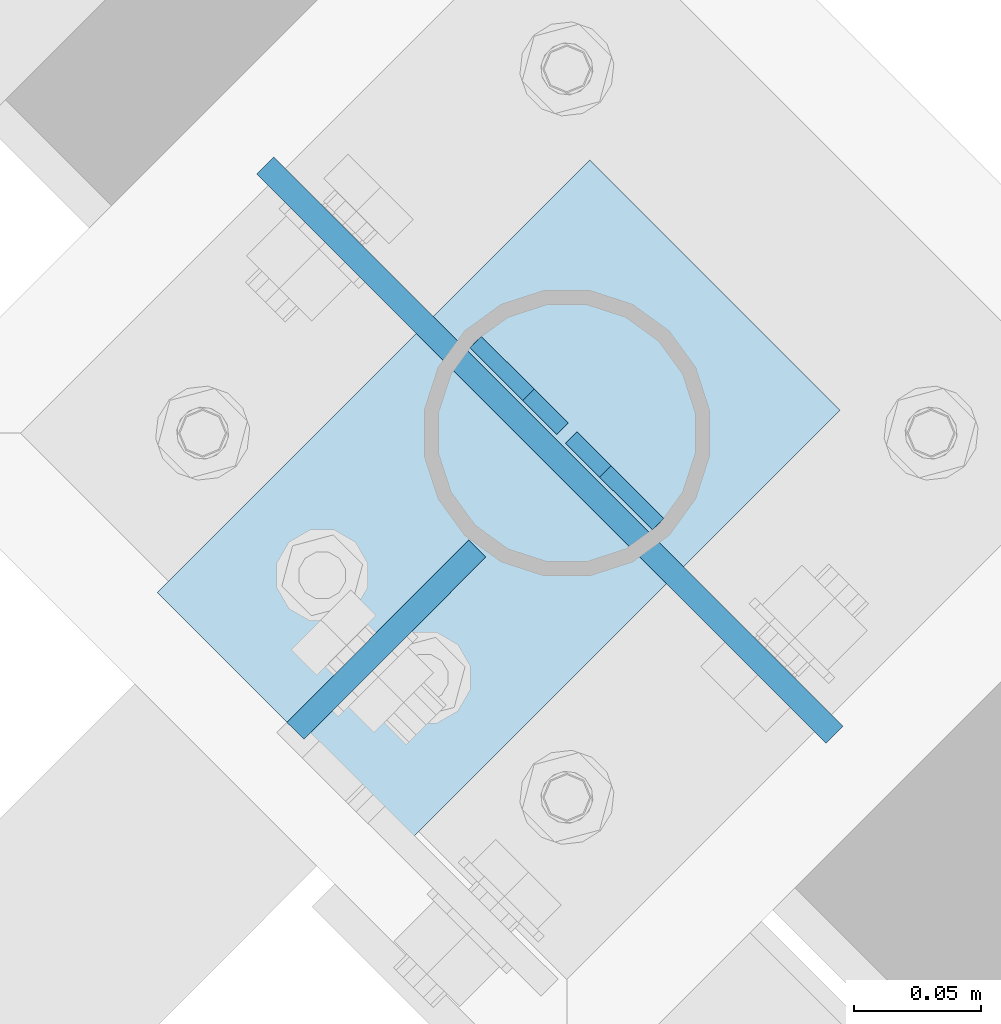
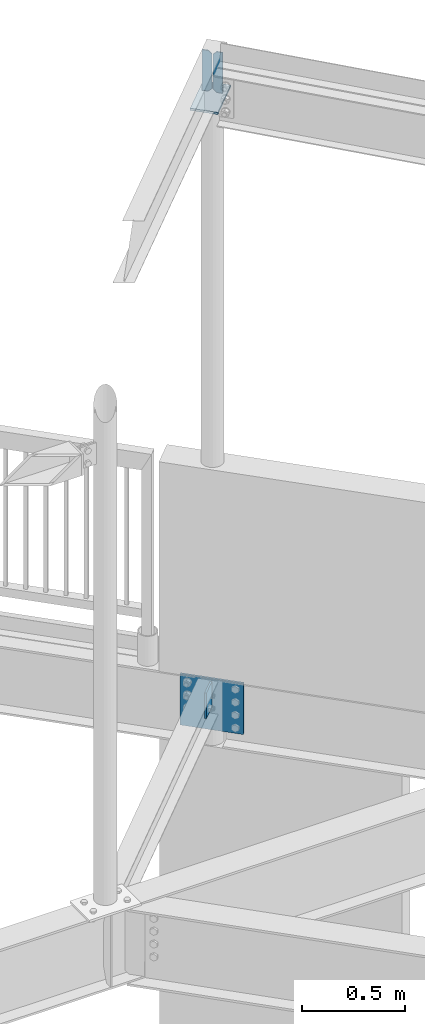
# One storey, part 869 of 975: 5 plates.
"""IFC2X3 building model written with IfcOpenShell, lengths in millimetres."""

from ifc_helpers import new_model, si_unit, frame, origin_with_axes, place, context, subcontext, project, spatial, faceted_brep, material, type_object, element, save


model = new_model("IFC2X3")

# Units and contexts
model_context = context("Model", 3, precision=1e-05, world=origin_with_axes())
body_context = subcontext(model_context, "Body", "Model", "MODEL_VIEW")
ifc_project = project(units=[si_unit("LENGTHUNIT", "METRE", prefix="MILLI"), si_unit("AREAUNIT", "SQUARE_METRE"), si_unit("VOLUMEUNIT", "CUBIC_METRE"), si_unit("MASSUNIT", "GRAM", prefix="KILO"), si_unit("TIMEUNIT", "SECOND"), si_unit("PLANEANGLEUNIT", "RADIAN"), si_unit("SOLIDANGLEUNIT", "STERADIAN"), si_unit("THERMODYNAMICTEMPERATUREUNIT", "DEGREE_CELSIUS"), si_unit("LUMINOUSINTENSITYUNIT", "LUMEN")], contexts=[model_context])

# Site, building, storey
site_placement = place(None, origin_with_axes())
site = spatial("IfcSite", under=ifc_project, at=site_placement, CompositionType="ELEMENT")
building_placement = place(site_placement, origin_with_axes())
building = spatial("IfcBuilding", under=site, at=building_placement, Name="Undefined", CompositionType="ELEMENT")
storey_placement = place(building_placement, origin_with_axes())
storey = spatial("IfcBuildingStorey", under=building, at=storey_placement, Name="Undefined", CompositionType="ELEMENT", Elevation=0.0)

# Plates
ifc_material = material(Name="STEEL/A36")
plate_type_1 = type_object("IfcPlateType", PredefinedType="NOTDEFINED")
plate_1_placement = place(storey_placement, frame((26520.3890966743, 22033.4454172632, 3911.6), z_axis=(-0.706311124041064, -0.707901544041153, 0.0), x_axis=(0.0, 0.0, -1.0)))
element("IfcPlate", 1, at=plate_1_placement, inside=storey, type_object=plate_type_1, material=ifc_material, Name="PLATE", context=body_context, shape_type="Brep", body=[
    faceted_brep([(0.0, -4.76250000000073, 0.0), (0.0, -4.76250000020354, 101.653930664019), (0.0, 4.76249999979427, 101.653930664033), (0.0, 4.76250000000073, 0.0), (152.399993896484, -4.76250000020354, 101.653930664019), (152.399993896484, 4.76249999979427, 101.653930664033), (152.399993896484, -4.76250000000073, 0.0), (152.399993896484, 4.76250000000073, 0.0)], [[[0, 1, 2, 3]], [[1, 4, 5, 2]], [[4, 6, 7, 5]], [[6, 0, 3, 7]], [[5, 7, 3, 2]], [[6, 4, 1, 0]]]),
])
plate_type_2 = type_object("IfcPlateType", PredefinedType="NOTDEFINED")
for number, where, z_axis, x_axis, name in (
    (2, (26591.6613986301, 22043.069394718, 7615.23749999999), (0.0, 0.0, -1.0), (-0.707901544041143, 0.706311124041074, 0.0), "PLATE"),
    (3, (26519.7386017587, 22114.8306049177, 7615.23749999999), (0.0, 0.0, -1.0), (0.707901544041155, -0.706311124041062, 0.0), "PLATE"),
):
    element("IfcPlate", number, at=place(storey_placement, frame(where, z_axis=z_axis, x_axis=x_axis)), inside=storey, type_object=plate_type_2, material=ifc_material, Name=name, context=body_context, shape_type="Brep", body=[
        faceted_brep([(0.0, -3.17499999999927, 0.0), (0.0, -3.17499999999927, 241.300003051758), (0.0, 3.17499999999927, 241.300003051758), (0.0, 3.17499999999927, 0.0), (29.3687515258025, -3.17499999977736, 241.300003051745), (29.3687515257989, 3.17500000021391, 241.300003051743), (48.4187507628649, -3.17499999980646, 222.250003814686), (48.4187507628576, 3.17500000018481, 222.250003814683), (48.4187507629249, -3.17500000000291, 19.0499992370424), (48.4187507629249, 3.17499999998836, 19.0499992370424), (29.3687515258753, -3.17500000001746, -1.09139364212751e-11), (29.3687515258716, 3.17499999998836, -1.09139364212751e-11)], [[[0, 1, 2, 3]], [[1, 4, 5, 2]], [[4, 6, 7, 5]], [[6, 8, 9, 7]], [[8, 10, 11, 9]], [[10, 0, 3, 11]], [[5, 7, 9, 11, 3, 2]], [[10, 8, 6, 4, 1, 0]]]),
    ])
plate_type_3 = type_object("IfcPlateType", PredefinedType="NOTDEFINED")
plate_2_placement = place(storey_placement, frame((26492.8382071579, 21917.305389821, 7362.825), z_axis=(0.707106781186548, 0.707106781186548, 0.0), x_axis=(-0.707106781186601, 0.707106781186494, 2.36468622460961e-14)))
element("IfcPlate", 4, at=plate_2_placement, inside=storey, type_object=plate_type_3, material=ifc_material, Name="PLATE", context=body_context, shape_type="Brep", body=[
    faceted_brep([(0.0, -6.34999999998763, -3.63797880709171e-12), (-2.80124368146062e-10, -6.34999999993306, 241.300003051925), (-2.92857293970883e-10, 6.35000000007312, 241.300003051925), (0.0, 6.34999999999491, 5.45696821063757e-12), (139.699996947658, -6.34999999996398, 241.300003051925), (139.699996947651, 6.3500000000422, 241.300003051932), (139.699996948082, -6.35000000003311, 8.73114913702011e-11), (139.699996948071, 6.34999999997308, 8.00355337560177e-11)], [[[0, 1, 2, 3]], [[1, 4, 5, 2]], [[4, 6, 7, 5]], [[6, 0, 3, 7]], [[5, 7, 3, 2]], [[6, 4, 1, 0]]]),
])
plate_type_4 = type_object("IfcPlateType", PredefinedType="NOTDEFINED")
plate_3_placement = place(storey_placement, frame((26598.0048880395, 22023.1828024953, 3898.9), z_axis=(0.0, 0.0, -1.0), x_axis=(-0.707165018788105, 0.707048538788122, 0.0)))
element("IfcPlate", 5, at=plate_3_placement, inside=storey, type_object=plate_type_4, material=ifc_material, Name="PLATE", context=body_context, shape_type="Brep", body=[
    faceted_brep([(0.0, -4.76250000000073, 0.0), (-89.4028701781281, -4.76250000013533, 0.0), (-89.4028701781444, 4.76249999985157, 0.0), (0.0, 4.76250000000073, 0.0), (-89.4028701781281, -4.76250000013533, 304.799987792969), (-89.4028701781444, 4.76249999985157, 304.799987792969), (228.097122192168, -4.76249999964784, 304.799987792969), (228.097122192152, 4.76250000033906, 304.799987792969), (228.097122192168, -4.76249999964784, 0.0), (228.097122192152, 4.76250000033906, 0.0)], [[[0, 1, 2, 3]], [[1, 4, 5, 2]], [[4, 6, 7, 5]], [[6, 8, 9, 7]], [[8, 0, 3, 9]], [[5, 7, 9, 3, 2]], [[8, 6, 4, 1, 0]]]),
])

save(model, "model.ifc")
